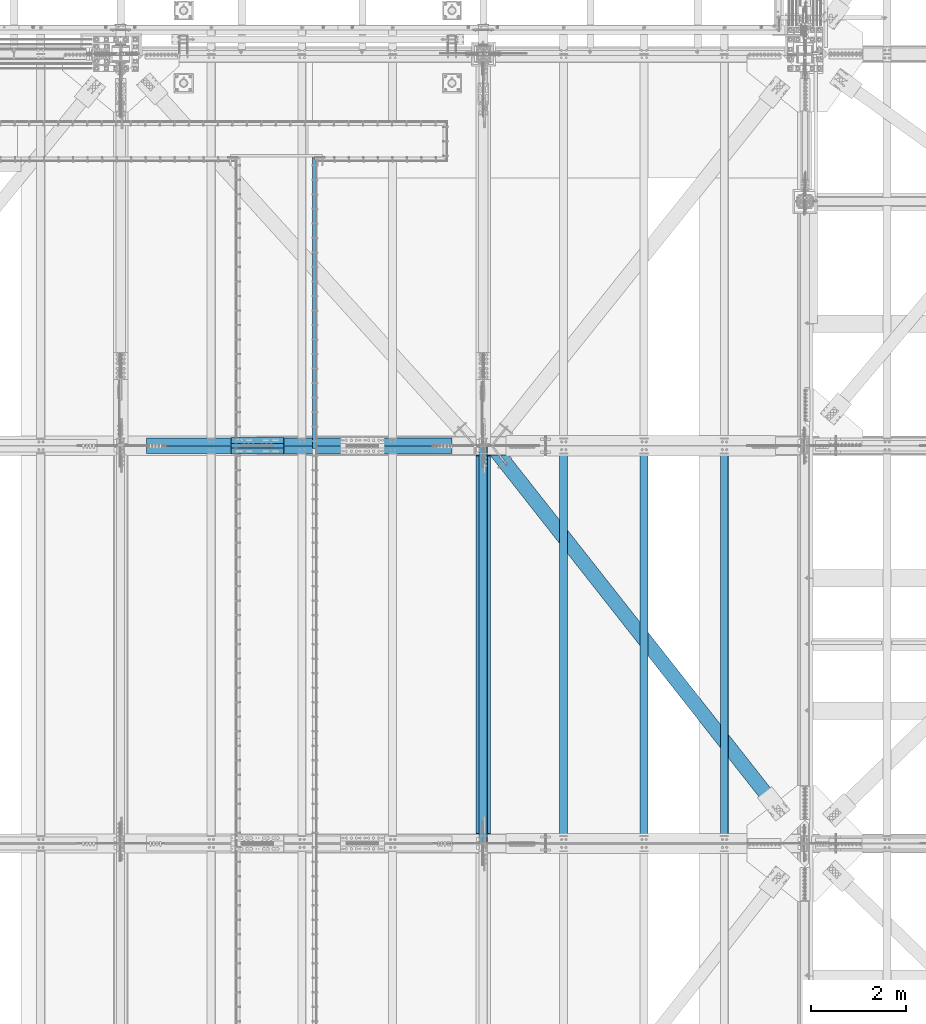
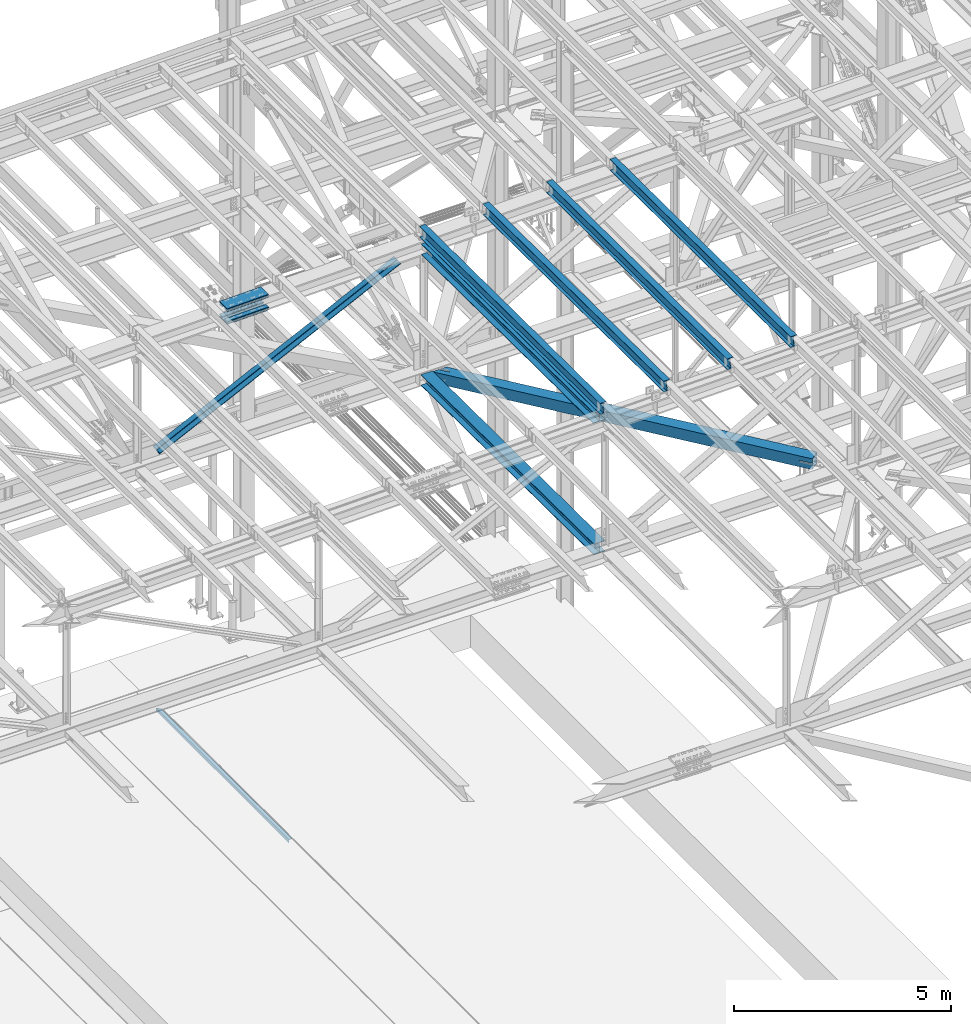
# One storey, part 1922 of 3843: 14 beams, 2 members, 11 elements without a shape of their own.
"""IFC2X3 building model written with IfcOpenShell, lengths in millimetres."""

from ifc_helpers import new_model, si_unit, frame, origin_with_axes, place, context, subcontext, project, spatial, faceted_brep, material, type_object, element, aggregate, save


model = new_model("IFC2X3")

# Units and contexts
model_context = context("Model", 3, precision=1e-05, world=origin_with_axes())
body_context = subcontext(model_context, "Body", "Model", "MODEL_VIEW")
ifc_project = project(units=[si_unit("LENGTHUNIT", "METRE", prefix="MILLI"), si_unit("AREAUNIT", "SQUARE_METRE"), si_unit("VOLUMEUNIT", "CUBIC_METRE"), si_unit("MASSUNIT", "GRAM", prefix="KILO"), si_unit("TIMEUNIT", "SECOND"), si_unit("PLANEANGLEUNIT", "RADIAN"), si_unit("SOLIDANGLEUNIT", "STERADIAN"), si_unit("THERMODYNAMICTEMPERATUREUNIT", "DEGREE_CELSIUS"), si_unit("LUMINOUSINTENSITYUNIT", "LUMEN")], contexts=[model_context])

# Site, building, storey
site_placement = place(None, origin_with_axes())
site = spatial("IfcSite", under=ifc_project, at=site_placement, CompositionType="ELEMENT")
building_placement = place(site_placement, origin_with_axes())
building = spatial("IfcBuilding", under=site, at=building_placement, Name="Undefined", CompositionType="ELEMENT")
storey_placement = place(building_placement, origin_with_axes())
storey = spatial("IfcBuildingStorey", under=building, at=storey_placement, Name="Undefined", CompositionType="ELEMENT", Elevation=0.0)

# Assembly, beam
assembly_1_placement = place(storey_placement, origin_with_axes())
assembly_1 = element("IfcElementAssembly", 1, at=assembly_1_placement, inside=storey, Name="EMBED_ANGLE", AssemblyPlace="NOTDEFINED", PredefinedType="RIGID_FRAME")
ifc_material_1 = material(Name="STEEL/A36")
beam_type_1 = type_object("IfcBeamType", Name="L3-1/2X3-1/2X5/16", PredefinedType="NOTDEFINED")
beam_1_placement = place(assembly_1_placement, frame((66713.8620000044, 90049.2224002759, 30410.15), z_axis=(0.0, 0.0, -1.0), x_axis=(0.0, -1.0, 0.0)))
beam_1 = element("IfcBeam", 2, at=beam_1_placement, type_object=beam_type_1, material=ifc_material_1, Name="EMBED_ANGLE", ObjectType="L3-1/2X3-1/2X5/16", context=body_context, shape_type="Brep", body=[
    faceted_brep([(-3.63797880709171e-12, 44.4499999999971, -44.4500000000007), (-3.63797880709171e-12, 44.4499999999971, 44.4500000000007), (6121.39969715093, 44.4499999999971, 44.4500000000007), (6121.39969715093, 44.4499999999971, -44.4500000000007), (7.93750032749085, 36.5124999999825, 44.4500000000007), (6121.39969715093, 36.5124999999971, 44.4500000000007), (7.93749960740388, 36.5125000000007, -36.5124999999825), (6121.39969715093, 36.5124999999971, -36.5125000000007), (88.9000039503298, -44.4500000001644, -36.5125000000007), (6121.39969715093, -44.4499999999971, -36.5125000000007), (88.8999999971129, -44.4500000000007, -44.4499999999971), (6121.39969715093, -44.4499999999971, -44.4500000000007)], [[[0, 1, 2, 3]], [[1, 4, 5, 2]], [[4, 6, 7, 5]], [[6, 8, 9, 7]], [[8, 10, 11, 9]], [[10, 0, 3, 11]], [[5, 7, 9, 11, 3, 2]], [[10, 8, 6, 4, 1, 0]]]),
])
aggregate(assembly_1, [beam_1])

assembly_2_placement = place(storey_placement, origin_with_axes())
assembly_2 = element("IfcElementAssembly", 3, at=assembly_2_placement, inside=storey, Name="BEAM", AssemblyPlace="NOTDEFINED", PredefinedType="RIGID_FRAME")
ifc_material_2 = material(Name="STEEL/A992")
beam_type_2 = type_object("IfcBeamType", Name="W12X26", PredefinedType="NOTDEFINED")
beam_2_placement = place(assembly_2_placement, frame((70253.1092623565, 75629.688193108, 46366.5704512022), z_axis=(-0.0211520981982467, 0.00763743000170506, 0.999747097222483), x_axis=(0.0, 0.999970817272395, -0.00763967300208123)))
beam_2 = element("IfcBeam", 4, at=beam_2_placement, type_object=beam_type_2, material=ifc_material_2, Name="BEAM", ObjectType="W12X26", context=body_context, shape_type="Brep", body=[
    faceted_brep([(12.7137097608211, 82.5499999999156, -155.575000000674), (12.6409611183917, 82.5499999999447, -146.05000000065), (8344.08406146776, 82.5500000000029, -146.050000002884), (8344.15681011017, 82.5499999999738, -155.575000002907), (12.6281350282952, 3.17499999950815, -146.050000000439), (8344.07123537765, 3.1749999995518, -146.050000002673), (10.3971766606119, 3.17500000051223, 146.050000000425), (8341.84027700998, 3.17500000057044, 146.049999998198), (10.4100027507229, 82.5500000009633, 146.050000000228), (8341.85310310009, 82.550000001007, 146.049999997987), (10.3372541083081, 82.5500000009924, 155.575000000252), (8341.78035445766, 82.5500000010361, 155.574999998018), (10.3105758408637, -82.5499999999302, 155.575000000681), (8341.75367619023, -82.5499999998865, 155.574999998447), (10.3833244832931, -82.5499999999593, 146.05000000065), (8341.82642483266, -82.5499999999156, 146.049999998417), (10.3961505734187, -3.1749999995227, 146.050000000447), (8341.83925092276, -3.17499999946449, 146.049999998213), (12.6271089410729, -3.17500000054133, -146.050000000425), (8344.07020929044, -3.17500000048312, -146.050000002659), (12.6142828509619, -82.5500000009779, -146.050000000221), (8344.05738320031, -82.5500000009197, -146.050000002448), (12.6870314933913, -82.550000001007, -155.575000000244), (8344.13013184274, -82.5500000009488, -155.575000002471)], [[[0, 1, 2, 3]], [[1, 4, 5, 2]], [[4, 6, 7, 5]], [[6, 8, 9, 7]], [[8, 10, 11, 9]], [[10, 12, 13, 11]], [[12, 14, 15, 13]], [[14, 16, 17, 15]], [[16, 18, 19, 17]], [[18, 20, 21, 19]], [[20, 22, 23, 21]], [[22, 0, 3, 23]], [[5, 7, 9, 11, 13, 15, 17, 19, 21, 23, 3, 2]], [[22, 20, 18, 16, 14, 12, 10, 8, 6, 4, 1, 0]]]),
])
aggregate(assembly_2, [beam_2])

assembly_3_placement = place(storey_placement, origin_with_axes())
assembly_3 = element("IfcElementAssembly", 5, at=assembly_3_placement, inside=storey, Name="BEAM", AssemblyPlace="NOTDEFINED", PredefinedType="RIGID_FRAME")
beam_3_placement = place(assembly_3_placement, frame((75320.4092623408, 75629.558391661, 46469.2499725647), z_axis=(-0.0211520977145119, 0.00680309599898463, 0.999753122849388), x_axis=(0.0, 0.999976848318922, -0.0068046180021706)))
beam_3 = element("IfcBeam", 6, at=beam_3_placement, type_object=beam_type_2, material=ifc_material_2, Name="BEAM", ObjectType="W12X26", context=body_context, shape_type="Brep", body=[
    faceted_brep([(12.7121758274152, 82.5500000009051, -155.57499999983), (12.6473748415883, 82.5500000008615, -146.04999999985), (8344.04026069198, 82.5500000008615, -146.049999999806), (8344.10506167781, 82.5500000009051, -155.574999999779), (12.6359499787213, 3.17500000043947, -146.049999999639), (8344.02883582911, 3.17500000043947, -146.049999999603), (10.6487197466922, 3.17499999959546, 146.049999999625), (8342.04160559707, 3.17499999959546, 146.049999999668), (10.6601446095447, 82.550000000032, 146.049999999428), (8342.05303045992, 82.550000000032, 146.049999999464), (10.5953436237323, 82.5500000000175, 155.5749999994), (8341.9882294741, 82.5500000000175, 155.574999999444), (10.5715799089667, -82.5500000009051, 155.574999999822), (8341.96446575935, -82.5500000009051, 155.574999999859), (10.6363808947935, -82.5500000008615, 146.049999999843), (8342.02926674517, -82.5500000008615, 146.049999999879), (10.6478057576605, -3.17500000042492, 146.049999999646), (8342.04069160804, -3.17500000042492, 146.049999999683), (12.6350359896896, -3.17499999959546, -146.049999999632), (8344.02792184008, -3.17499999959546, -146.049999999595), (12.6236111268372, -82.550000000032, -146.049999999428), (8344.01649697723, -82.550000000032, -146.049999999384), (12.6884121126641, -82.5500000000029, -155.574999999408), (8344.08129796304, -82.5500000000029, -155.574999999364)], [[[0, 1, 2, 3]], [[1, 4, 5, 2]], [[4, 6, 7, 5]], [[6, 8, 9, 7]], [[8, 10, 11, 9]], [[10, 12, 13, 11]], [[12, 14, 15, 13]], [[14, 16, 17, 15]], [[16, 18, 19, 17]], [[18, 20, 21, 19]], [[20, 22, 23, 21]], [[22, 0, 3, 23]], [[5, 7, 9, 11, 13, 15, 17, 19, 21, 23, 3, 2]], [[22, 20, 18, 16, 14, 12, 10, 8, 6, 4, 1, 0]]]),
])
aggregate(assembly_3, [beam_3])

assembly_4_placement = place(storey_placement, origin_with_axes())
assembly_4 = element("IfcElementAssembly", 7, at=assembly_4_placement, inside=storey, Name="BEAM", AssemblyPlace="NOTDEFINED", PredefinedType="RIGID_FRAME")
beam_4_placement = place(assembly_4_placement, frame((73631.3092623419, 75629.6113977849, 46435.5466754253), z_axis=(-0.0211520979914349, 0.0071438070022996, 0.999750746322339), x_axis=(0.0, 0.999974471260676, -0.00714540600186267)))
beam_4 = element("IfcBeam", 8, at=beam_4_placement, type_object=beam_type_2, material=ifc_material_2, Name="BEAM", ObjectType="W12X26", context=body_context, shape_type="Brep", body=[
    faceted_brep([(12.712801221307, 82.5500000002212, -155.575000000201), (12.6447547190619, 82.5500000002357, -146.050000000199), (8344.05744508645, 82.5500000002066, -146.049999998817), (8344.12549158871, 82.5500000001921, -155.574999998811), (12.6327576489566, 3.17499999978463, -146.050000000003), (8344.04544801635, 3.17499999975553, -146.049999998606), (10.54599824654, 3.17500000022119, 146.049999999996), (8341.95868861394, 3.17500000019209, 146.050000001393), (10.5579953166452, 82.5500000006723, 146.049999999792), (8341.97068568405, 82.5500000006432, 146.050000001182), (10.4899488144001, 82.5500000007014, 155.574999999793), (8341.9026391818, 82.5500000006723, 155.575000001183), (10.464994908587, -82.5500000002503, 155.575000000215), (8341.87768527598, -82.5500000002648, 155.575000001605), (10.5330414108321, -82.5500000002503, 146.050000000214), (8341.94573177824, -82.5500000002794, 146.050000001604), (10.5450384809228, -3.17499999979918, 146.05000000001), (8341.95772884833, -3.17499999982829, 146.0500000014), (12.6317978833395, -3.17500000026484, -146.049999999974), (8344.04448825074, -3.1750000002794, -146.049999998591), (12.6198008132196, -82.5500000007014, -146.049999999785), (8344.03249118062, -82.5500000007305, -146.049999998388), (12.6878473154793, -82.550000000716, -155.574999999779), (8344.10053768288, -82.5500000007451, -155.574999998389)], [[[0, 1, 2, 3]], [[1, 4, 5, 2]], [[4, 6, 7, 5]], [[6, 8, 9, 7]], [[8, 10, 11, 9]], [[10, 12, 13, 11]], [[12, 14, 15, 13]], [[14, 16, 17, 15]], [[16, 18, 19, 17]], [[18, 20, 21, 19]], [[20, 22, 23, 21]], [[22, 0, 3, 23]], [[5, 7, 9, 11, 13, 15, 17, 19, 21, 23, 3, 2]], [[22, 20, 18, 16, 14, 12, 10, 8, 6, 4, 1, 0]]]),
])
aggregate(assembly_4, [beam_4])

assembly_5_placement = place(storey_placement, origin_with_axes())
assembly_5 = element("IfcElementAssembly", 9, at=assembly_5_placement, inside=storey, Name="BEAM", AssemblyPlace="NOTDEFINED", PredefinedType="RIGID_FRAME")
beam_5_placement = place(assembly_5_placement, frame((71942.2092623103, 75629.6541276273, 46401.2912987181), z_axis=(-0.0211520983124356, 0.00741846499993701, 0.999748745992725), x_axis=(0.0, 0.999972470493528, -0.00742012500366195)))
beam_5 = element("IfcBeam", 10, at=beam_5_placement, type_object=beam_type_2, material=ifc_material_2, Name="BEAM", ObjectType="W12X26", context=body_context, shape_type="Brep", body=[
    faceted_brep([(12.7133063615038, 82.5500000014144, -155.574999999611), (12.6426435381291, 82.5500000013562, -146.049999999617), (8344.07200374454, 82.5500000011671, -146.049999991206), (8344.14266656792, 82.5500000012253, -155.574999991193), (12.6301851926255, 3.17500000091968, -146.049999999756), (8344.05954539905, 3.17500000073051, -146.049999991337), (10.4631919422391, 3.17499999911524, 146.049999999785), (8341.89255214868, 3.17499999892607, 146.050000008203), (10.4756502877281, 82.5499999995372, 146.049999999923), (8341.90501049416, 82.5499999993626, 146.050000008334), (10.4049874643533, 82.5499999994936, 155.57499999991), (8341.83434767077, 82.5499999993044, 155.575000008321), (10.3790741057455, -82.5500000014144, 155.574999999626), (8341.80843431216, -82.5500000016036, 155.575000008044), (10.4497369291203, -82.5500000013417, 146.049999999639), (8341.87909713555, -82.5500000015309, 146.050000008057), (10.4621952746093, -3.17500000093423, 146.04999999977), (8341.89155548104, -3.17500000110886, 146.050000008188), (12.6291885249957, -3.17499999911524, -146.049999999763), (8344.05854873141, -3.17499999930442, -146.049999991352), (12.6167301795067, -82.5499999995518, -146.049999999901), (8344.04609038593, -82.549999999741, -146.04999999149), (12.687393002896, -82.5499999994936, -155.574999999888), (8344.11675320931, -82.5499999996828, -155.57499999147)], [[[0, 1, 2, 3]], [[1, 4, 5, 2]], [[4, 6, 7, 5]], [[6, 8, 9, 7]], [[8, 10, 11, 9]], [[10, 12, 13, 11]], [[12, 14, 15, 13]], [[14, 16, 17, 15]], [[16, 18, 19, 17]], [[18, 20, 21, 19]], [[20, 22, 23, 21]], [[22, 0, 3, 23]], [[5, 7, 9, 11, 13, 15, 17, 19, 21, 23, 3, 2]], [[22, 20, 18, 16, 14, 12, 10, 8, 6, 4, 1, 0]]]),
])
aggregate(assembly_5, [beam_5])

# Assembly, beams
assembly_6_placement = place(storey_placement, origin_with_axes())
assembly_6 = element("IfcElementAssembly", 11, at=assembly_6_placement, inside=storey, Name="BEAM", AssemblyPlace="NOTDEFINED", PredefinedType="RIGID_FRAME")
ifc_material_3 = material(Name="STEEL/A572-50")
beam_type_3 = type_object("IfcBeamType", PredefinedType="NOTDEFINED")
beam_6_placement = place(assembly_6_placement, frame((66066.3734284201, 84099.4, 45711.9582630634), z_axis=(0.0, -1.0, 0.0), x_axis=(-0.999765952267441, 0.0, -0.0216342480057875)))
beam_6 = element("IfcBeam", 12, at=beam_6_placement, type_object=beam_type_3, material=ifc_material_3, Name="PLATE", context=body_context, shape_type="Brep", body=[
    faceted_brep([(-4.36557456851006e-11, 12.7000000000116, -63.5), (-4.36557456851006e-11, 12.7000000000116, 63.5), (1104.90000001677, 12.7000000017251, 63.5), (1104.90000001677, 12.7000000017251, -63.5), (1.45519152283669e-11, -12.700000000008, 63.5), (1104.90000001682, -12.6999999982909, 63.5), (1.45519152283669e-11, -12.700000000008, -63.5), (1104.90000001682, -12.6999999982909, -63.5)], [[[0, 1, 2, 3]], [[1, 4, 5, 2]], [[4, 6, 7, 5]], [[6, 0, 3, 7]], [[5, 7, 3, 2]], [[6, 4, 1, 0]]]),
])
beam_7_placement = place(assembly_6_placement, frame((66059.9853758439, 84099.4, 46007.1641544555), z_axis=(0.0, -1.0, 0.0), x_axis=(-0.999765952267441, 0.0, -0.0216342480057875)))
beam_7 = element("IfcBeam", 13, at=beam_7_placement, type_object=beam_type_3, material=ifc_material_3, Name="PLATE", context=body_context, shape_type="Brep", body=[
    faceted_brep([(-4.36557456851006e-11, 12.7000000000116, -63.5), (-4.36557456851006e-11, 12.7000000000116, 63.5), (1104.90000001677, 12.7000000017251, 63.5), (1104.90000001677, 12.7000000017251, -63.5), (1.45519152283669e-11, -12.700000000008, 63.5), (1104.90000001682, -12.6999999982909, 63.5), (1.45519152283669e-11, -12.700000000008, -63.5), (1104.90000001682, -12.6999999982909, -63.5)], [[[0, 1, 2, 3]], [[1, 4, 5, 2]], [[4, 6, 7, 5]], [[6, 0, 3, 7]], [[5, 7, 3, 2]], [[6, 4, 1, 0]]]),
])
beam_8_placement = place(assembly_6_placement, frame((66066.3734284201, 83870.8, 45711.9582630634), z_axis=(0.0, -1.0, 0.0), x_axis=(-0.999765952267441, 0.0, -0.0216342480057875)))
beam_8 = element("IfcBeam", 14, at=beam_8_placement, type_object=beam_type_3, material=ifc_material_3, Name="PLATE", context=body_context, shape_type="Brep", body=[
    faceted_brep([(-4.36557456851006e-11, 12.7000000000116, -63.5), (-4.36557456851006e-11, 12.7000000000116, 63.5), (1104.90000001677, 12.7000000017251, 63.5), (1104.90000001677, 12.7000000017251, -63.5), (1.45519152283669e-11, -12.700000000008, 63.5), (1104.90000001682, -12.6999999982909, 63.5), (1.45519152283669e-11, -12.700000000008, -63.5), (1104.90000001682, -12.6999999982909, -63.5)], [[[0, 1, 2, 3]], [[1, 4, 5, 2]], [[4, 6, 7, 5]], [[6, 0, 3, 7]], [[5, 7, 3, 2]], [[6, 4, 1, 0]]]),
])
beam_9_placement = place(assembly_6_placement, frame((66059.9853758439, 83870.8, 46007.1641544555), z_axis=(0.0, -1.0, 0.0), x_axis=(-0.999765952267441, 0.0, -0.0216342480057875)))
beam_9 = element("IfcBeam", 15, at=beam_9_placement, type_object=beam_type_3, material=ifc_material_3, Name="PLATE", context=body_context, shape_type="Brep", body=[
    faceted_brep([(-4.36557456851006e-11, 12.7000000000116, -63.5), (-4.36557456851006e-11, 12.7000000000116, 63.5), (1104.90000001677, 12.7000000017251, 63.5), (1104.90000001677, 12.7000000017251, -63.5), (1.45519152283669e-11, -12.700000000008, 63.5), (1104.90000001682, -12.6999999982909, 63.5), (1.45519152283669e-11, -12.700000000008, -63.5), (1104.90000001682, -12.6999999982909, -63.5)], [[[0, 1, 2, 3]], [[1, 4, 5, 2]], [[4, 6, 7, 5]], [[6, 0, 3, 7]], [[5, 7, 3, 2]], [[6, 4, 1, 0]]]),
])
beam_type_4 = type_object("IfcBeamType", PredefinedType="NOTDEFINED")
beam_10_placement = place(assembly_6_placement, frame((64963.0714581262, 83985.1, 45626.1565727509), z_axis=(0.0, -1.0, 0.0), x_axis=(0.999765952267441, 0.0, 0.0216342480057898)))
beam_10 = element("IfcBeam", 16, at=beam_10_placement, type_object=beam_type_4, material=ifc_material_3, Name="PLATE", context=body_context, shape_type="Brep", body=[
    faceted_brep([(-1.45519152283669e-11, 12.7000000000025, -177.800000000003), (-1.45519152283669e-11, 12.7000000000025, 177.800000000003), (1104.90000001682, 12.7000000017051, 177.800000000003), (1104.90000001682, 12.7000000017051, -177.800000000003), (4.36557456851006e-11, -12.7000000000171, 177.800000000003), (1104.90000001686, -12.6999999983072, 177.800000000003), (4.36557456851006e-11, -12.7000000000171, -177.800000000003), (1104.90000001686, -12.6999999983072, -177.800000000003)], [[[0, 1, 2, 3]], [[1, 4, 5, 2]], [[4, 6, 7, 5]], [[6, 0, 3, 7]], [[5, 7, 3, 2]], [[6, 4, 1, 0]]]),
])
beam_11_placement = place(assembly_6_placement, frame((64954.0045447833, 83985.1, 46045.1584835253), z_axis=(0.0, -1.0, 0.0), x_axis=(0.999765952267441, 0.0, 0.0216342480057898)))
beam_11 = element("IfcBeam", 17, at=beam_11_placement, type_object=beam_type_4, material=ifc_material_3, Name="PLATE", context=body_context, shape_type="Brep", body=[
    faceted_brep([(-1.45519152283669e-11, 12.7000000000025, -177.800000000003), (-1.45519152283669e-11, 12.7000000000025, 177.800000000003), (1104.90000001682, 12.7000000017051, 177.800000000003), (1104.90000001682, 12.7000000017051, -177.800000000003), (4.36557456851006e-11, -12.7000000000171, 177.800000000003), (1104.90000001686, -12.6999999983072, 177.800000000003), (4.36557456851006e-11, -12.7000000000171, -177.800000000003), (1104.90000001686, -12.6999999983072, -177.800000000003)], [[[0, 1, 2, 3]], [[1, 4, 5, 2]], [[4, 6, 7, 5]], [[6, 0, 3, 7]], [[5, 7, 3, 2]], [[6, 4, 1, 0]]]),
])
aggregate(assembly_6, [beam_6, beam_7, beam_8, beam_9, beam_10, beam_11])

# Assembly, member
assembly_7_placement = place(storey_placement, origin_with_axes())
assembly_7 = element("IfcElementAssembly", 18, at=assembly_7_placement, inside=storey, Name="ANGLE", AssemblyPlace="NOTDEFINED", PredefinedType="RIGID_FRAME")
member_type = type_object("IfcMemberType", Name="L6X6X1/2", PredefinedType="NOTDEFINED")
member_1_placement = place(assembly_7_placement, frame((70256.4000021063, 84070.825, 45950.2996159692), z_axis=(0.0, 1.0, 0.0), x_axis=(-0.89997067391171, 0.0, -0.435950439957231)))
member_1 = element("IfcMember", 19, at=member_1_placement, type_object=member_type, material=ifc_material_3, Name="ANGLE", ObjectType="L6X6X1/2", context=body_context, shape_type="Brep", body=[
    faceted_brep([(700.157648391585, 76.2000000021199, -76.1999999999971), (700.157648391585, 76.2000000021199, 76.1999999999971), (7827.75698675959, 76.200000021754, 76.1999999999971), (7827.75698675959, 76.200000021754, -76.1999999999971), (700.157648391498, 63.5000000020864, 76.1999999999971), (7827.7569867595, 63.5000000217169, 76.1999999999971), (700.157648391498, 63.5000000020864, -63.5), (7827.7569867595, 63.5000000217169, -63.5), (700.157648390581, -76.1999999982672, -63.5), (7827.7569867586, -76.1999999786331, -63.5), (700.157648390581, -76.1999999982672, -76.1999999999971), (7827.7569867586, -76.1999999786331, -76.1999999999971)], [[[0, 1, 2, 3]], [[1, 4, 5, 2]], [[4, 6, 7, 5]], [[6, 8, 9, 7]], [[8, 10, 11, 9]], [[10, 0, 3, 11]], [[5, 7, 9, 11, 3, 2]], [[10, 8, 6, 4, 1, 0]]]),
])
aggregate(assembly_7, [member_1])

assembly_8_placement = place(storey_placement, origin_with_axes())
assembly_8 = element("IfcElementAssembly", 20, at=assembly_8_placement, inside=storey, Name="ANGLE", AssemblyPlace="NOTDEFINED", PredefinedType="RIGID_FRAME")
member_2_placement = place(assembly_8_placement, frame((62636.4, 83899.375, 42259.1323534987), z_axis=(0.0, -1.0, 0.0), x_axis=(0.899970673911709, 0.0, 0.435950439957233)))
member_2 = element("IfcMember", 21, at=member_2_placement, type_object=member_type, material=ifc_material_3, Name="ANGLE", ObjectType="L6X6X1/2", context=body_context, shape_type="Brep", body=[
    faceted_brep([(639.185570310525, 76.199999998189, -76.1999999999971), (639.185570310525, 76.199999998189, 76.1999999999971), (7766.78490867853, 76.1999999785585, 76.1999999999971), (7766.78490867853, 76.1999999785585, -76.1999999999971), (639.185570310525, 63.4999999981956, 76.1999999999971), (7766.78490867854, 63.499999978565, 76.1999999999971), (639.185570310525, 63.4999999981956, -63.5), (7766.78490867854, 63.499999978565, -63.5), (639.185570310525, -76.2000000017106, -63.5), (7766.78490867854, -76.2000000213447, -63.5), (639.185570310525, -76.2000000017106, -76.1999999999971), (7766.78490867854, -76.2000000213447, -76.1999999999971)], [[[0, 1, 2, 3]], [[1, 4, 5, 2]], [[4, 6, 7, 5]], [[6, 8, 9, 7]], [[8, 10, 11, 9]], [[10, 0, 3, 11]], [[5, 7, 9, 11, 3, 2]], [[10, 8, 6, 4, 1, 0]]]),
])
aggregate(assembly_8, [member_2])

# Assembly, beam
assembly_9_placement = place(storey_placement, origin_with_axes())
assembly_9 = element("IfcElementAssembly", 22, at=assembly_9_placement, inside=storey, AssemblyPlace="NOTDEFINED", PredefinedType="RIGID_FRAME")
ifc_material_4 = material()
beam_type_5 = type_object("IfcBeamType", Name="HSS12X12X3/4", PredefinedType="NOTDEFINED")
beam_12_placement = place(assembly_9_placement, frame((70434.1999995667, 83985.10000053, 42246.55), z_axis=(0.785737876999385, 0.618559607999504, 0.0), x_axis=(0.618559605792669, -0.78573787873668, 0.0)))
beam_12 = element("IfcBeam", 23, at=beam_12_placement, type_object=beam_type_5, material=ifc_material_4, ObjectType="HSS12X12X3/4", context=body_context, shape_type="Brep", body=[
    faceted_brep([(263.797084437931, -152.400000000001, 14.2878088949947), (263.797084437931, -133.349999999999, 14.2878088949947), (497.314262842257, -133.349999999999, 14.2880819877464), (497.314262842257, -152.400000000001, 14.2880819877464), (502.781853800516, -133.349999999999, 13.2005171734636), (502.781853800516, -152.400000000001, 13.2005171734636), (507.417056142811, -133.349999999999, 10.1033818264114), (507.417056142811, -152.400000000001, 10.1033818264114), (510.514202330611, -133.349999999999, 5.46818672768131), (510.514202330611, -152.400000000001, 5.46818672768131), (497.314296260025, -152.400000000001, -14.2869180113194), (497.314296260025, -133.349999999999, -14.2869180113194), (241.301850965538, -133.349999999999, -14.2872174117219), (241.301850965538, -152.400000000001, -14.2872174117219), (502.781884673423, -152.400000000001, -13.1993404090463), (502.781884673423, -133.349999999999, -13.1993404090463), (507.417079771076, -152.400000000001, -10.1021942217048), (507.417079771076, -133.349999999999, -10.1021942217048), (510.514215117684, -152.400000000001, -5.4669918804866), (510.514215117684, -133.349999999999, -5.4669918804866), (511.601779932411, -152.400000000001, 0.000598313010414131), (511.601779932411, -133.349999999999, 0.000598313010414131), (263.797084437931, 133.349999999999, 14.2878088949947), (263.797084437931, 152.400000000001, 14.2878088949947), (497.314262842257, 152.400000000001, 14.2880819877464), (497.314262842257, 133.349999999999, 14.2880819877464), (502.781853800516, 152.400000000001, 13.2005171734636), (502.781853800516, 133.349999999999, 13.2005171734636), (507.417056142811, 152.400000000001, 10.1033818264114), (507.417056142811, 133.349999999999, 10.1033818264114), (510.514202330611, 152.400000000001, 5.46818672768131), (510.514202330611, 133.349999999999, 5.46818672768131), (497.314296260025, 133.349999999999, -14.2869180113194), (497.314296260025, 152.400000000001, -14.2869180113194), (241.301850965538, 152.400000000001, -14.2872174117219), (241.301850965538, 133.349999999999, -14.2872174117219), (502.781884673423, 133.349999999999, -13.1993404090463), (502.781884673423, 152.400000000001, -13.1993404090463), (507.417079771076, 133.349999999999, -10.1021942217048), (507.417079771076, 152.400000000001, -10.1021942217048), (510.514215117684, 133.349999999999, -5.4669918804866), (510.514215117684, 152.400000000001, -5.4669918804866), (511.601779932411, 133.349999999999, 0.000598313010414131), (511.601779932411, 152.400000000001, 0.000598313010414131), (9569.43131133494, -26.9881270982369, -133.350000041377), (9569.43131133494, -26.9881270982369, -152.400000041249), (9266.21881193782, -26.9881270982369, -152.40000003991), (9266.21881189603, -26.9881270982369, -133.350000040024), (9260.75122225197, -25.9005558899516, -152.400000039881), (9260.75122221019, -25.9005558899516, -133.350000040009), (9256.11602353198, -22.8034151227112, -152.400000039866), (9256.1160234902, -22.8034151227112, -133.35000003998), (9253.01888276477, -18.1682164026643, -152.400000039852), (9253.01888272298, -18.1682164026643, -133.35000003998), (9251.93131155649, -12.7006267167671, -152.400000039852), (9251.9313115147, -12.7006267167671, -133.350000039965), (9253.01888276477, -7.2330377938124, -152.400000039852), (9253.01888272298, -7.2330377938124, -133.35000003998), (9256.11602353198, -2.5978390737655, -152.400000039866), (9256.1160234902, -2.5978390737655, -133.35000003998), (9260.75122225197, 0.49930169347499, -152.400000039881), (9260.75122221019, 0.49930169347499, -133.350000040009), (9266.21881193782, 1.58687290176022, -152.40000003991), (9266.21881189603, 1.58687290176022, -133.350000040024), (9569.43131133494, 1.58687290176022, -133.350000041377), (9569.43131133494, 1.58687290176022, -152.400000041249), (9569.43132448789, 133.349999999999, 133.349999971222), (9569.43132374003, 133.349999999999, -133.350000029735), (9569.43132368661, 152.400000000001, -152.400000029804), (9569.43132454131, 152.400000000001, 152.399999971291), (9569.43131133492, 1.58687290176022, 152.399999956877), (9569.43131133492, 1.58687290176022, 133.349999957005), (9569.43132374003, -133.349999999999, -133.350000029735), (147.571575323949, 133.349999999999, -133.349999999831), (147.571575323949, -133.349999999999, -133.349999999831), (357.526894441988, -133.349999999999, 133.349999997605), (9569.43132448789, -133.349999999999, 133.349999971222), (9266.21881131107, 1.58687290176022, 133.349999958344), (9260.75122162523, 0.49930169347499, 133.349999958344), (9256.11602290523, -2.5978390737655, 133.349999958373), (9253.01888213801, -7.2330377938124, 133.349999958387), (9251.93131092974, -12.7006267167671, 133.349999958387), (9253.01888213801, -18.1682164026643, 133.349999958387), (9256.11602290523, -22.8034151227112, 133.349999958373), (9260.75122162523, -25.9005558899516, 133.349999958344), (9266.21881131107, -26.9881270982369, 133.349999958344), (9569.43131133492, -26.9881270982369, 133.349999957005), (357.526894441988, 133.349999999999, 133.349999997605), (9266.21881126929, 1.58687290176022, 152.399999958216), (9260.75122158344, 0.49930169347499, 152.399999958245), (9256.11602286344, -2.5978390737655, 152.399999958259), (9253.01888209624, -7.2330377938124, 152.399999958274), (9251.93131088796, -12.7006267167671, 152.399999958274), (9253.01888209624, -18.1682164026643, 152.399999958274), (9256.11602286344, -22.8034151227112, 152.399999958259), (9260.75122158344, -25.9005558899516, 152.399999958245), (9266.21881126929, -26.9881270982369, 152.399999958216), (9569.43131133492, -26.9881270982369, 152.399999956877), (9569.43132454131, -152.400000000001, 152.399999971291), (9569.43132368661, -152.400000000001, -152.400000029804), (132.574766815516, -152.400000000001, -152.399999999659), (132.574766815516, 152.400000000001, -152.399999999659), (372.523702950406, 152.400000000001, 152.399999997418), (372.523702950406, -152.400000000001, 152.399999997418)], [[[0, 1, 2, 3]], [[3, 2, 4, 5]], [[5, 4, 6, 7]], [[7, 6, 8, 9]], [[10, 11, 12, 13]], [[14, 15, 11, 10]], [[16, 17, 15, 14]], [[18, 19, 17, 16]], [[20, 21, 19, 18]], [[9, 8, 21, 20]], [[22, 23, 24, 25]], [[25, 24, 26, 27]], [[27, 26, 28, 29]], [[29, 28, 30, 31]], [[32, 33, 34, 35]], [[36, 37, 33, 32]], [[38, 39, 37, 36]], [[40, 41, 39, 38]], [[42, 43, 41, 40]], [[31, 30, 43, 42]], [[44, 45, 46, 47]], [[47, 46, 48, 49]], [[49, 48, 50, 51]], [[51, 50, 52, 53]], [[53, 52, 54, 55]], [[55, 54, 56, 57]], [[57, 56, 58, 59]], [[59, 58, 60, 61]], [[61, 60, 62, 63]], [[64, 63, 62, 65]], [[66, 67, 64, 65, 68, 69, 70, 71]], [[72, 44, 47, 49, 51, 53, 55, 57, 59, 61, 63, 64, 67, 73, 74]], [[6, 4, 2, 1, 75, 76, 72, 74, 12, 11, 15, 17, 19, 21, 8]], [[66, 71, 77, 78, 79, 80, 81, 82, 83, 84, 85, 86, 76, 75, 87]], [[70, 88, 77, 71]], [[89, 78, 77, 88]], [[90, 79, 78, 89]], [[91, 80, 79, 90]], [[92, 81, 80, 91]], [[93, 82, 81, 92]], [[94, 83, 82, 93]], [[95, 84, 83, 94]], [[96, 85, 84, 95]], [[97, 86, 85, 96]], [[98, 99, 45, 44, 72, 76, 86, 97]], [[68, 65, 62, 60, 58, 56, 54, 52, 50, 48, 46, 45, 99, 100, 101]], [[74, 73, 35, 34, 101, 100, 13, 12]], [[28, 26, 24, 23, 102, 69, 68, 101, 34, 33, 37, 39, 41, 43, 30]], [[98, 97, 96, 95, 94, 93, 92, 91, 90, 89, 88, 70, 69, 102, 103]], [[16, 14, 10, 13, 100, 99, 98, 103, 0, 3, 5, 7, 9, 20, 18]], [[103, 102, 23, 22, 87, 75, 1, 0]], [[38, 36, 32, 35, 73, 67, 66, 87, 22, 25, 27, 29, 31, 42, 40]]]),
])
aggregate(assembly_9, [beam_12])

assembly_10_placement = place(storey_placement, origin_with_axes())
assembly_10 = element("IfcElementAssembly", 24, at=assembly_10_placement, inside=storey, Name="BEAM", AssemblyPlace="NOTDEFINED", PredefinedType="RIGID_FRAME")
beam_type_6 = type_object("IfcBeamType", Name="W12X65", PredefinedType="NOTDEFINED")
beam_13_placement = place(assembly_10_placement, frame((70256.4, 75628.4999999989, 46014.1431761287), z_axis=(0.0, 0.00763967300207875, 0.999970817272395), x_axis=(0.0, 0.999970817272395, -0.00763967300208123)))
beam_13 = element("IfcBeam", 25, at=beam_13_placement, type_object=beam_type_6, material=ifc_material_2, Name="BEAM", ObjectType="W12X65", context=body_context, shape_type="Brep", body=[
    faceted_brep([(213.907656554991, 152.399999999994, -153.987499999057), (213.786373206705, 152.399999999994, -138.112499999115), (8145.16783249807, 152.399999999994, -138.112499983486), (8145.28911584636, 152.399999999994, -153.987499983436), (213.786373206705, 4.76249999999709, -138.112499999115), (8145.16783249807, 4.76249999999709, -138.112499983486), (211.676042946521, 4.76249999999709, 138.112499999959), (8143.05750223789, 4.76249999999709, 138.112500015581), (211.676042946521, 152.399999999994, 138.112499999959), (8143.05750223789, 152.399999999994, 138.112500015581), (211.554759598235, 152.399999999994, 153.987499999901), (8142.9362188896, 152.399999999994, 153.98750001553), (211.554759598235, -152.399999999994, 153.987499999901), (8142.9362188896, -152.399999999994, 153.98750001553), (211.676042946521, -152.399999999994, 138.112499999959), (8143.05750223789, -152.399999999994, 138.112500015581), (211.676042946521, -4.76249999999709, 138.112499999959), (8143.05750223789, -4.76249999999709, 138.112500015581), (213.786373206705, -4.76249999999709, -138.112499999115), (8145.16783249807, -4.76249999999709, -138.112499983486), (213.786373206705, -152.399999999994, -138.112499999115), (8145.16783249807, -152.399999999994, -138.112499983486), (213.907656554991, -152.399999999994, -153.987499999057), (8145.28911584636, -152.399999999994, -153.987499983436)], [[[0, 1, 2, 3]], [[1, 4, 5, 2]], [[4, 6, 7, 5]], [[6, 8, 9, 7]], [[8, 10, 11, 9]], [[10, 12, 13, 11]], [[12, 14, 15, 13]], [[14, 16, 17, 15]], [[16, 18, 19, 17]], [[18, 20, 21, 19]], [[20, 22, 23, 21]], [[22, 0, 3, 23]], [[5, 7, 9, 11, 13, 15, 17, 19, 21, 23, 3, 2]], [[22, 20, 18, 16, 14, 12, 10, 8, 6, 4, 1, 0]]]),
])
aggregate(assembly_10, [beam_13])

assembly_11_placement = place(storey_placement, origin_with_axes())
assembly_11 = element("IfcElementAssembly", 26, at=assembly_11_placement, inside=storey, Name="BEAM", AssemblyPlace="NOTDEFINED", PredefinedType="RIGID_FRAME")
beam_14_placement = place(assembly_11_placement, frame((70256.4, 75628.4999999989, 42326.6716433361), z_axis=(0.0, 0.00764166900016427, 0.999970802021185), x_axis=(0.0, 0.999970802021185, -0.00764166900016207)))
beam_14 = element("IfcBeam", 27, at=beam_14_placement, type_object=beam_type_6, material=ifc_material_2, Name="BEAM", ObjectType="W12X65", context=body_context, shape_type="Brep", body=[
    faceted_brep([(199.620050007259, 152.399999999994, -153.98749999937), (199.498734969733, 152.399999999994, -138.112499999421), (8159.45614959716, 152.399999999994, -138.112499990195), (8159.57746463468, 152.399999999994, -153.987499990159), (199.498734969733, 4.76249999999709, -138.112499999421), (8159.45614959716, 4.76249999999709, -138.112499990195), (197.387853316686, 4.76249999999709, 138.112499999879), (8157.34526794411, 4.76249999999709, 138.112500009098), (197.387853316686, 152.399999999994, 138.112499999879), (8157.34526794411, 152.399999999994, 138.112500009098), (197.266538279146, 152.399999999994, 153.987499999843), (8157.22395290658, 152.399999999994, 153.987500009054), (197.266538279146, -152.399999999994, 153.987499999843), (8157.22395290658, -152.399999999994, 153.987500009054), (197.387853316686, -152.399999999994, 138.112499999879), (8157.34526794411, -152.399999999994, 138.112500009098), (197.387853316686, -4.76249999999709, 138.112499999879), (8157.34526794411, -4.76249999999709, 138.112500009098), (199.498734969733, -4.76249999999709, -138.112499999421), (8159.45614959716, -4.76249999999709, -138.112499990195), (199.498734969733, -152.399999999994, -138.112499999421), (8159.45614959716, -152.399999999994, -138.112499990195), (199.620050007259, -152.399999999994, -153.98749999937), (8159.57746463468, -152.399999999994, -153.987499990159)], [[[0, 1, 2, 3]], [[1, 4, 5, 2]], [[4, 6, 7, 5]], [[6, 8, 9, 7]], [[8, 10, 11, 9]], [[10, 12, 13, 11]], [[12, 14, 15, 13]], [[14, 16, 17, 15]], [[16, 18, 19, 17]], [[18, 20, 21, 19]], [[20, 22, 23, 21]], [[22, 0, 3, 23]], [[5, 7, 9, 11, 13, 15, 17, 19, 21, 23, 3, 2]], [[22, 20, 18, 16, 14, 12, 10, 8, 6, 4, 1, 0]]]),
])
aggregate(assembly_11, [beam_14])

save(model, "model.ifc")
